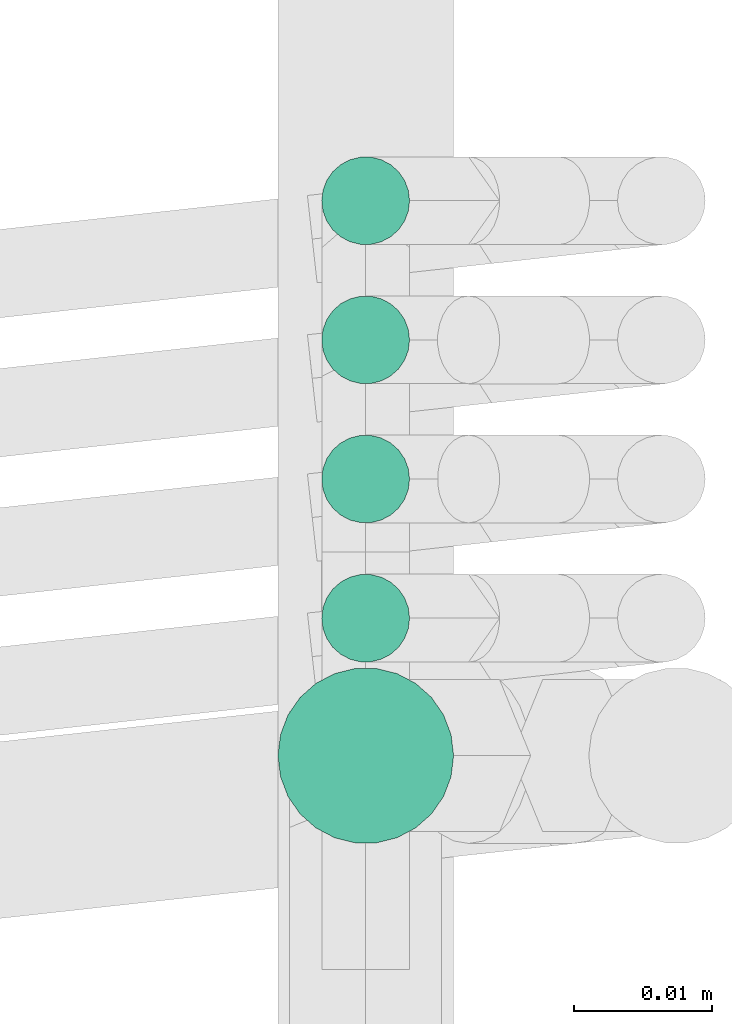
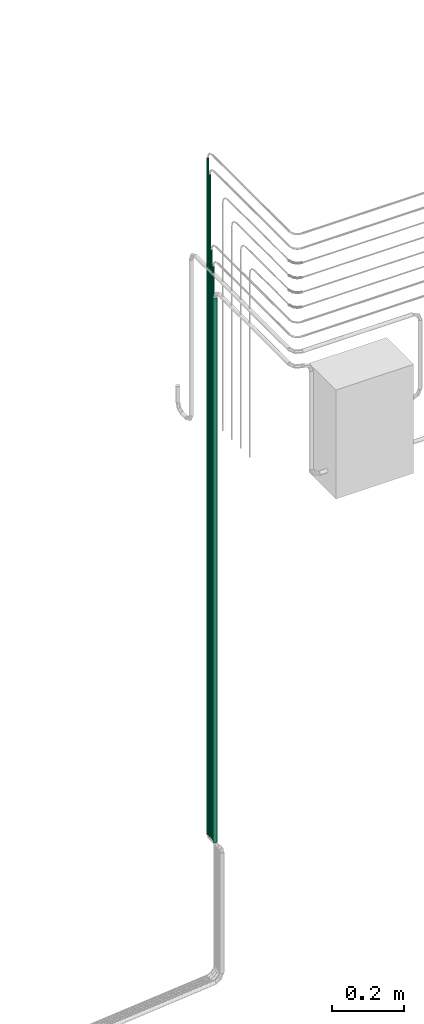
# One storey, part 5 of 45: 5 flow segments.
"""IFC2X3 building model written with IfcOpenShell, lengths in millimetres."""

from ifc_helpers import new_model, entity, si_unit, converted_unit, derived_unit, direction, frame, origin, origin_2d_with_axis, place, context, subcontext, project, spatial, circle, extrude, type_object, element, save


model = new_model("IFC2X3")

# Units and contexts
model_context = context("Model", 3, precision=0.01, world=origin(), true_north=direction((6.12303176911189e-17, 1.0)))
body_context = subcontext(model_context, "Body", "Model", "MODEL_VIEW")
ifc_project = project(units=[si_unit("LENGTHUNIT", "METRE", prefix="MILLI"), si_unit("AREAUNIT", "SQUARE_METRE"), si_unit("VOLUMEUNIT", "CUBIC_METRE"), converted_unit("PLANEANGLEUNIT", "DEGREE", entity("IfcRatioMeasure", 0.0174532925199433), si_unit("PLANEANGLEUNIT", "RADIAN"), dimensions=[0, 0, 0, 0, 0, 0, 0]), si_unit("MASSUNIT", "GRAM", prefix="KILO"), derived_unit("MASSDENSITYUNIT", [(si_unit("MASSUNIT", "GRAM", prefix="KILO"), 1), (si_unit("LENGTHUNIT", "METRE"), -3)]), derived_unit("MOMENTOFINERTIAUNIT", [(si_unit("LENGTHUNIT", "METRE"), 4)]), si_unit("TIMEUNIT", "SECOND"), si_unit("FREQUENCYUNIT", "HERTZ"), si_unit("THERMODYNAMICTEMPERATUREUNIT", "DEGREE_CELSIUS"), derived_unit("THERMALTRANSMITTANCEUNIT", [(si_unit("MASSUNIT", "GRAM", prefix="KILO"), 1), (si_unit("THERMODYNAMICTEMPERATUREUNIT", "KELVIN"), -1), (si_unit("TIMEUNIT", "SECOND"), -3)]), derived_unit("VOLUMETRICFLOWRATEUNIT", [(si_unit("LENGTHUNIT", "METRE"), 3), (si_unit("TIMEUNIT", "SECOND"), -1)]), derived_unit("MASSFLOWRATEUNIT", [(si_unit("MASSUNIT", "GRAM", prefix="KILO"), 1), (si_unit("TIMEUNIT", "SECOND"), -1)]), derived_unit("ROTATIONALFREQUENCYUNIT", [(si_unit("TIMEUNIT", "SECOND"), -1)]), si_unit("ELECTRICCURRENTUNIT", "AMPERE"), si_unit("ELECTRICVOLTAGEUNIT", "VOLT"), si_unit("POWERUNIT", "WATT"), si_unit("FORCEUNIT", "NEWTON", prefix="KILO"), si_unit("ILLUMINANCEUNIT", "LUX"), si_unit("LUMINOUSFLUXUNIT", "LUMEN"), si_unit("LUMINOUSINTENSITYUNIT", "CANDELA"), derived_unit("USERDEFINED", [(si_unit("MASSUNIT", "GRAM", prefix="KILO"), -1), (si_unit("LENGTHUNIT", "METRE"), -2), (si_unit("TIMEUNIT", "SECOND"), 3), (si_unit("LUMINOUSFLUXUNIT", "LUMEN"), 1)]), derived_unit("LINEARVELOCITYUNIT", [(si_unit("LENGTHUNIT", "METRE"), 1), (si_unit("TIMEUNIT", "SECOND"), -1)]), si_unit("PRESSUREUNIT", "PASCAL"), derived_unit("USERDEFINED", [(si_unit("LENGTHUNIT", "METRE"), -2), (si_unit("MASSUNIT", "GRAM", prefix="KILO"), 1), (si_unit("TIMEUNIT", "SECOND"), -2)]), derived_unit("LINEARFORCEUNIT", [(si_unit("MASSUNIT", "GRAM", prefix="KILO"), 1), (si_unit("LENGTHUNIT", "METRE"), 1), (si_unit("TIMEUNIT", "SECOND"), -2), (si_unit("LENGTHUNIT", "METRE"), -1)]), derived_unit("PLANARFORCEUNIT", [(si_unit("MASSUNIT", "GRAM", prefix="KILO"), 1), (si_unit("LENGTHUNIT", "METRE"), 1), (si_unit("TIMEUNIT", "SECOND"), -2), (si_unit("LENGTHUNIT", "METRE"), -2)])], contexts=[model_context])

# Site, building, storey
site_placement = place(None, frame((-24836.06, 8968.75, 0.0)))
site = spatial("IfcSite", under=ifc_project, at=site_placement, CompositionType="ELEMENT")
building_placement = place(site_placement, origin())
building = spatial("IfcBuilding", under=site, at=building_placement, CompositionType="ELEMENT")
storey_placement = place(building_placement, frame((0.0, 0.0, -4200.0)))
storey = spatial("IfcBuildingStorey", under=building, at=storey_placement, CompositionType="ELEMENT", Elevation=-4200.0)

# Flow segments
pipe_segment_type = type_object("IfcPipeSegmentType", PredefinedType="NOTDEFINED")
flow_segment_1_placement = place(storey_placement, frame((80740.98, -7113.83, 76.9)))
element("IfcFlowSegment", 1, at=flow_segment_1_placement, inside=storey, type_object=pipe_segment_type, context=body_context, shape_type="SweptSolid", body=[
    extrude(circle(Radius=3.175, at=origin_2d_with_axis()), frame((4.77, 4.77, 0.0), z_axis=(0.0, 0.0, 1.0), x_axis=(-1.0, 0.0, 0.0)), (0.0, 0.0, 1.0), 2297.70141225818),
])
flow_segment_2_placement = place(storey_placement, frame((80740.98, -7144.01, 76.9)))
element("IfcFlowSegment", 2, at=flow_segment_2_placement, inside=storey, type_object=pipe_segment_type, context=body_context, shape_type="SweptSolid", body=[
    extrude(circle(Radius=3.175, at=origin_2d_with_axis()), frame((4.77, 4.77, 0.0), z_axis=(0.0, 0.0, 1.0), x_axis=(-1.0, 0.0, 0.0)), (0.0, 0.0, 1.0), 1947.70141225807),
])
flow_segment_3_placement = place(storey_placement, frame((80740.98, -7133.95, 76.9)))
element("IfcFlowSegment", 3, at=flow_segment_3_placement, inside=storey, type_object=pipe_segment_type, context=body_context, shape_type="SweptSolid", body=[
    extrude(circle(Radius=3.175, at=origin_2d_with_axis()), frame((4.77, 4.77, 0.0), z_axis=(0.0, 0.0, 1.0), x_axis=(-1.0, 0.0, 0.0)), (0.0, 0.0, 1.0), 1997.70141225804),
])
flow_segment_4_placement = place(storey_placement, frame((80740.98, -7123.89, 76.9)))
element("IfcFlowSegment", 4, at=flow_segment_4_placement, inside=storey, type_object=pipe_segment_type, context=body_context, shape_type="SweptSolid", body=[
    extrude(circle(Radius=3.175, at=origin_2d_with_axis()), frame((4.77, 4.77, 0.0), z_axis=(0.0, 0.0, 1.0), x_axis=(-1.0, 0.0, 0.0)), (0.0, 0.0, 1.0), 2247.70141225804),
])
flow_segment_5_placement = place(storey_placement, frame((80737.81, -7157.13, 76.9)))
element("IfcFlowSegment", 5, at=flow_segment_5_placement, inside=storey, type_object=pipe_segment_type, context=body_context, shape_type="SweptSolid", body=[
    extrude(circle(Radius=6.35, at=origin_2d_with_axis()), frame((7.95, 7.95, 0.0), z_axis=(0.0, 0.0, 1.0), x_axis=(-1.0, 0.0, 0.0)), (0.0, 0.0, 1.0), 1847.70141225805),
])

save(model, "model.ifc")
